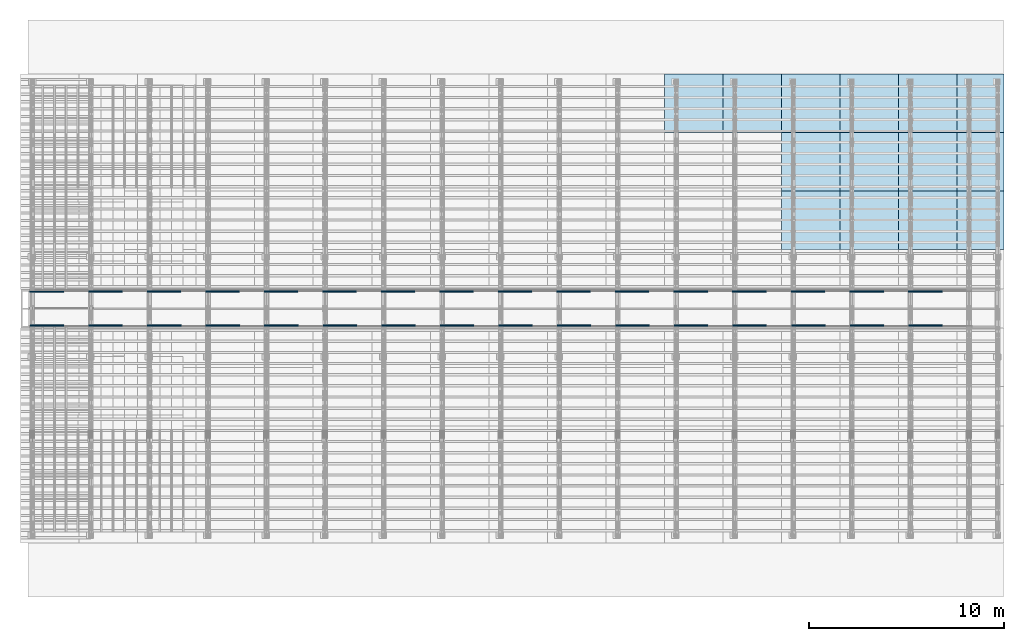
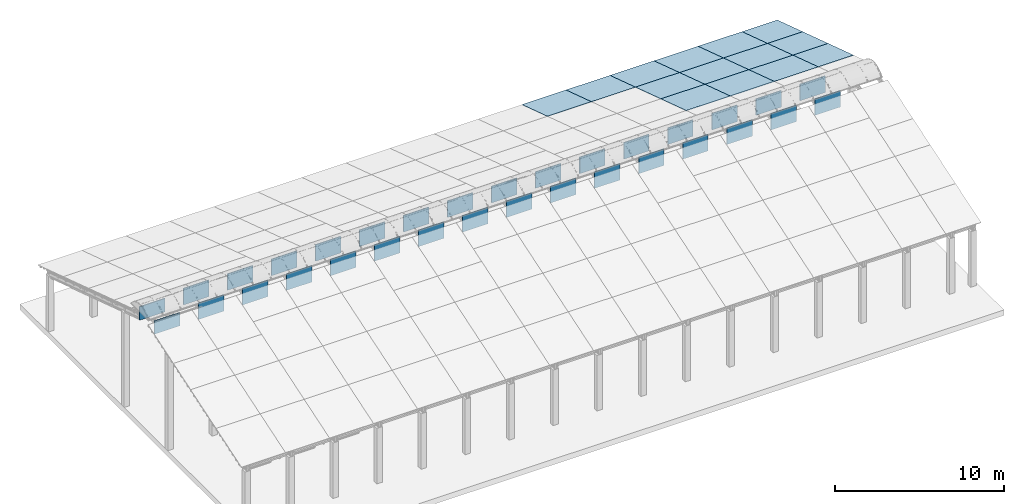
# One storey, part 10 of 385: 32 walls, 14 slabs, 14 elements without a shape of their own.
"""IFC2X3 building model written with IfcOpenShell, lengths in millimetres."""

from ifc_helpers import new_model, entity, si_unit, converted_unit, derived_unit, direction, frame, frame_2d, origin, place, context, subcontext, project, spatial, rectangle, extrude, material, layer, layer_set, layer_usage, type_object, element, aggregate, save


model = new_model("IFC2X3")

# Units and contexts
model_context = context("Model", 3, precision=0.01, world=origin(), true_north=direction((6.12303176911189e-17, 1.0)))
body_context = subcontext(model_context, "Body", "Model", "MODEL_VIEW")
ifc_project = project(units=[si_unit("LENGTHUNIT", "METRE", prefix="MILLI"), si_unit("AREAUNIT", "SQUARE_METRE"), si_unit("VOLUMEUNIT", "CUBIC_METRE"), converted_unit("PLANEANGLEUNIT", "DEGREE", entity("IfcRatioMeasure", 0.0174532925199433), si_unit("PLANEANGLEUNIT", "RADIAN"), dimensions=[0, 0, 0, 0, 0, 0, 0]), si_unit("MASSUNIT", "GRAM", prefix="KILO"), derived_unit("MASSDENSITYUNIT", [(si_unit("MASSUNIT", "GRAM", prefix="KILO"), 1), (si_unit("LENGTHUNIT", "METRE"), -3)]), si_unit("TIMEUNIT", "SECOND"), si_unit("FREQUENCYUNIT", "HERTZ"), si_unit("THERMODYNAMICTEMPERATUREUNIT", "DEGREE_CELSIUS"), derived_unit("THERMALTRANSMITTANCEUNIT", [(si_unit("MASSUNIT", "GRAM", prefix="KILO"), 1), (si_unit("THERMODYNAMICTEMPERATUREUNIT", "KELVIN"), -1), (si_unit("TIMEUNIT", "SECOND"), -3)]), derived_unit("VOLUMETRICFLOWRATEUNIT", [(si_unit("LENGTHUNIT", "METRE"), 3), (si_unit("TIMEUNIT", "SECOND"), -1)]), si_unit("ELECTRICCURRENTUNIT", "AMPERE"), si_unit("ELECTRICVOLTAGEUNIT", "VOLT"), si_unit("POWERUNIT", "WATT"), si_unit("FORCEUNIT", "NEWTON", prefix="KILO"), si_unit("ILLUMINANCEUNIT", "LUX"), si_unit("LUMINOUSFLUXUNIT", "LUMEN"), si_unit("LUMINOUSINTENSITYUNIT", "CANDELA"), derived_unit("USERDEFINED", [(si_unit("MASSUNIT", "GRAM", prefix="KILO"), -1), (si_unit("LENGTHUNIT", "METRE"), -2), (si_unit("TIMEUNIT", "SECOND"), 3), (si_unit("LUMINOUSFLUXUNIT", "LUMEN"), 1)]), derived_unit("LINEARVELOCITYUNIT", [(si_unit("LENGTHUNIT", "METRE"), 1), (si_unit("TIMEUNIT", "SECOND"), -1)]), si_unit("PRESSUREUNIT", "PASCAL"), derived_unit("USERDEFINED", [(si_unit("LENGTHUNIT", "METRE"), -2), (si_unit("MASSUNIT", "GRAM", prefix="KILO"), 1), (si_unit("TIMEUNIT", "SECOND"), -2)])], contexts=[model_context])

# Site, building, storey
site_placement = place(None, origin())
site = spatial("IfcSite", under=ifc_project, at=site_placement, CompositionType="ELEMENT")
building_placement = place(site_placement, origin())
building = spatial("IfcBuilding", under=site, at=building_placement, CompositionType="ELEMENT")
storey_placement = place(building_placement, origin())
storey = spatial("IfcBuildingStorey", under=building, at=storey_placement, Name="Default", CompositionType="ELEMENT", Elevation=0.0)

# Roof, slab
roof_1_placement = place(storey_placement, frame((32674.5090412161, 23742.4435684861, 594.897947736069)))
roof_1 = element("IfcRoof", 1, at=roof_1_placement, inside=storey, ShapeType="NOTDEFINED")
ifc_material_1 = material()
ifc_layer_1 = layer(ifc_material_1, 40.0)
ifc_layer_set_1 = layer_set([ifc_layer_1])
slab_1_placement = place(roof_1_placement, origin())
slab_1 = element("IfcSlab", 2, at=slab_1_placement, material=ifc_layer_set_1, PredefinedType="ROOF", context=body_context, shape_type="SweptSolid", body=[
    extrude(rectangle(XDim=3154.3866727148, YDim=2999.99999999999, at=frame_2d((0.0, 2.1600499167107e-12), x_axis=(0.0, 1.0))), frame((1500.0, 1500.0, 487.379544349359), z_axis=(0.0, 0.309016994374947, 0.951056516295154), x_axis=(1.0, 0.0, 0.0)), (0.0, -0.309016994374947, 0.951056516295154), 42.0584889695308),
])
aggregate(roof_1, [slab_1])

roof_2_placement = place(storey_placement, frame((35674.5090412161, 23742.4435684861, 594.897947736069)))
roof_2 = element("IfcRoof", 3, at=roof_2_placement, inside=storey, ShapeType="NOTDEFINED")
slab_2_placement = place(roof_2_placement, origin())
slab_2 = element("IfcSlab", 4, at=slab_2_placement, material=ifc_layer_set_1, PredefinedType="ROOF", context=body_context, shape_type="SweptSolid", body=[
    extrude(rectangle(XDim=3154.3866727148, YDim=2999.99999999999, at=frame_2d((0.0, 2.1600499167107e-12), x_axis=(0.0, 1.0))), frame((1500.0, 1500.0, 487.379544349359), z_axis=(0.0, 0.309016994374947, 0.951056516295154), x_axis=(1.0, 0.0, 0.0)), (0.0, -0.309016994374947, 0.951056516295154), 42.0584889695308),
])
aggregate(roof_2, [slab_2])

roof_3_placement = place(storey_placement, frame((38674.5090412161, 23742.4435684861, 594.897947736069)))
roof_3 = element("IfcRoof", 5, at=roof_3_placement, inside=storey, ShapeType="NOTDEFINED")
slab_3_placement = place(roof_3_placement, origin())
slab_3 = element("IfcSlab", 6, at=slab_3_placement, material=ifc_layer_set_1, PredefinedType="ROOF", context=body_context, shape_type="SweptSolid", body=[
    extrude(rectangle(XDim=3154.3866727148, YDim=2999.99999999999, at=frame_2d((-2.1600499167107e-12, 2.1600499167107e-12), x_axis=(0.0, 1.0))), frame((1500.0, 1500.0, 487.379544349359), z_axis=(0.0, 0.309016994374947, 0.951056516295154), x_axis=(1.0, 0.0, 0.0)), (0.0, -0.309016994374947, 0.951056516295154), 42.0584889695308),
])
aggregate(roof_3, [slab_3])

roof_4_placement = place(storey_placement, frame((38674.5090412161, 20742.4435684861, 1569.65703643478)))
roof_4 = element("IfcRoof", 7, at=roof_4_placement, inside=storey, ShapeType="NOTDEFINED")
slab_4_placement = place(roof_4_placement, origin())
slab_4 = element("IfcSlab", 8, at=slab_4_placement, material=ifc_layer_set_1, PredefinedType="ROOF", context=body_context, shape_type="SweptSolid", body=[
    extrude(rectangle(XDim=3154.3866727148, YDim=2999.99999999999, at=frame_2d((-2.1600499167107e-12, 1.13686837721616e-13), x_axis=(0.0, 1.0))), frame((1500.0, 1500.0, 487.379544349359), z_axis=(0.0, 0.309016994374947, 0.951056516295154), x_axis=(1.0, 0.0, 0.0)), (0.0, -0.309016994374947, 0.951056516295154), 42.0584889695308),
])
aggregate(roof_4, [slab_4])

roof_5_placement = place(storey_placement, frame((38674.5090412161, 17742.4435684861, 2544.4161251335)))
roof_5 = element("IfcRoof", 9, at=roof_5_placement, inside=storey, ShapeType="NOTDEFINED")
slab_5_placement = place(roof_5_placement, origin())
slab_5 = element("IfcSlab", 10, at=slab_5_placement, material=ifc_layer_set_1, PredefinedType="ROOF", context=body_context, shape_type="SweptSolid", body=[
    extrude(rectangle(XDim=3154.3866727148, YDim=2999.99999999999, at=frame_2d((-2.1600499167107e-12, 1.13686837721616e-12), x_axis=(0.0, 1.0))), frame((1500.0, 1500.0, 487.379544349359), z_axis=(0.0, 0.309016994374947, 0.951056516295154), x_axis=(1.0, 0.0, 0.0)), (0.0, -0.309016994374947, 0.951056516295154), 42.0584889695308),
])
aggregate(roof_5, [slab_5])

roof_6_placement = place(storey_placement, frame((41674.5090412161, 23742.443568486, 594.897947736069)))
roof_6 = element("IfcRoof", 11, at=roof_6_placement, inside=storey, ShapeType="NOTDEFINED")
slab_6_placement = place(roof_6_placement, origin())
slab_6 = element("IfcSlab", 12, at=slab_6_placement, material=ifc_layer_set_1, PredefinedType="ROOF", context=body_context, shape_type="SweptSolid", body=[
    extrude(rectangle(XDim=3154.3866727148, YDim=2999.99999999999, at=frame_2d((0.0, 2.1600499167107e-12), x_axis=(0.0, 1.0))), frame((1500.0, 1500.0, 487.379544349359), z_axis=(0.0, 0.309016994374947, 0.951056516295154), x_axis=(1.0, 0.0, 0.0)), (0.0, -0.309016994374947, 0.951056516295154), 42.0584889695308),
])
aggregate(roof_6, [slab_6])

roof_7_placement = place(storey_placement, frame((41674.5090412161, 20742.443568486, 1569.65703643478)))
roof_7 = element("IfcRoof", 13, at=roof_7_placement, inside=storey, ShapeType="NOTDEFINED")
slab_7_placement = place(roof_7_placement, origin())
slab_7 = element("IfcSlab", 14, at=slab_7_placement, material=ifc_layer_set_1, PredefinedType="ROOF", context=body_context, shape_type="SweptSolid", body=[
    extrude(rectangle(XDim=3154.3866727148, YDim=2999.99999999999, at=frame_2d((0.0, 1.13686837721616e-13), x_axis=(0.0, 1.0))), frame((1500.0, 1500.0, 487.379544349359), z_axis=(0.0, 0.309016994374947, 0.951056516295154), x_axis=(1.0, 0.0, 0.0)), (0.0, -0.309016994374947, 0.951056516295154), 42.0584889695308),
])
aggregate(roof_7, [slab_7])

roof_8_placement = place(storey_placement, frame((41674.5090412161, 17742.443568486, 2544.4161251335)))
roof_8 = element("IfcRoof", 15, at=roof_8_placement, inside=storey, ShapeType="NOTDEFINED")
slab_8_placement = place(roof_8_placement, origin())
slab_8 = element("IfcSlab", 16, at=slab_8_placement, material=ifc_layer_set_1, PredefinedType="ROOF", context=body_context, shape_type="SweptSolid", body=[
    extrude(rectangle(XDim=3154.3866727148, YDim=2999.99999999999, at=frame_2d((0.0, 1.13686837721616e-12), x_axis=(0.0, 1.0))), frame((1500.0, 1500.0, 487.379544349359), z_axis=(0.0, 0.309016994374947, 0.951056516295154), x_axis=(1.0, 0.0, 0.0)), (0.0, -0.309016994374947, 0.951056516295154), 42.0584889695308),
])
aggregate(roof_8, [slab_8])

roof_9_placement = place(storey_placement, frame((44674.5090412161, 23742.443568486, 594.897947736069)))
roof_9 = element("IfcRoof", 17, at=roof_9_placement, inside=storey, ShapeType="NOTDEFINED")
slab_9_placement = place(roof_9_placement, origin())
slab_9 = element("IfcSlab", 18, at=slab_9_placement, material=ifc_layer_set_1, PredefinedType="ROOF", context=body_context, shape_type="SweptSolid", body=[
    extrude(rectangle(XDim=3154.3866727148, YDim=2999.99999999999, at=frame_2d((0.0, 2.1600499167107e-12), x_axis=(0.0, 1.0))), frame((1500.0, 1500.0, 487.379544349359), z_axis=(0.0, 0.309016994374947, 0.951056516295154), x_axis=(1.0, 0.0, 0.0)), (0.0, -0.309016994374947, 0.951056516295154), 42.0584889695308),
])
aggregate(roof_9, [slab_9])

roof_10_placement = place(storey_placement, frame((44674.5090412161, 20742.443568486, 1569.65703643478)))
roof_10 = element("IfcRoof", 19, at=roof_10_placement, inside=storey, ShapeType="NOTDEFINED")
slab_10_placement = place(roof_10_placement, origin())
slab_10 = element("IfcSlab", 20, at=slab_10_placement, material=ifc_layer_set_1, PredefinedType="ROOF", context=body_context, shape_type="SweptSolid", body=[
    extrude(rectangle(XDim=3154.3866727148, YDim=2999.99999999999, at=frame_2d((0.0, 1.13686837721616e-13), x_axis=(0.0, 1.0))), frame((1500.0, 1500.0, 487.379544349359), z_axis=(0.0, 0.309016994374947, 0.951056516295154), x_axis=(1.0, 0.0, 0.0)), (0.0, -0.309016994374947, 0.951056516295154), 42.0584889695308),
])
aggregate(roof_10, [slab_10])

roof_11_placement = place(storey_placement, frame((44674.5090412161, 17742.443568486, 2544.4161251335)))
roof_11 = element("IfcRoof", 21, at=roof_11_placement, inside=storey, ShapeType="NOTDEFINED")
slab_11_placement = place(roof_11_placement, origin())
slab_11 = element("IfcSlab", 22, at=slab_11_placement, material=ifc_layer_set_1, PredefinedType="ROOF", context=body_context, shape_type="SweptSolid", body=[
    extrude(rectangle(XDim=3154.3866727148, YDim=2999.99999999999, at=frame_2d((0.0, 1.13686837721616e-12), x_axis=(0.0, 1.0))), frame((1500.0, 1500.0, 487.379544349359), z_axis=(0.0, 0.309016994374947, 0.951056516295154), x_axis=(1.0, 0.0, 0.0)), (0.0, -0.309016994374947, 0.951056516295154), 42.0584889695308),
])
aggregate(roof_11, [slab_11])

roof_12_placement = place(storey_placement, frame((47674.5090412161, 23742.443568486, 594.897947736069)))
roof_12 = element("IfcRoof", 23, at=roof_12_placement, inside=storey, ShapeType="NOTDEFINED")
slab_12_placement = place(roof_12_placement, origin())
slab_12 = element("IfcSlab", 24, at=slab_12_placement, material=ifc_layer_set_1, PredefinedType="ROOF", context=body_context, shape_type="SweptSolid", body=[
    extrude(rectangle(XDim=3154.3866727148, YDim=2400.0, at=frame_2d((4.32009983342141e-12, 2.1600499167107e-12), x_axis=(0.0, 1.0))), frame((1200.0, 1500.0, 487.379544349359), z_axis=(0.0, 0.309016994374947, 0.951056516295154), x_axis=(1.0, 0.0, 0.0)), (0.0, -0.309016994374947, 0.951056516295154), 42.0584889695308),
])
aggregate(roof_12, [slab_12])

roof_13_placement = place(storey_placement, frame((47674.5090412161, 20742.443568486, 1569.65703643478)))
roof_13 = element("IfcRoof", 25, at=roof_13_placement, inside=storey, ShapeType="NOTDEFINED")
slab_13_placement = place(roof_13_placement, origin())
slab_13 = element("IfcSlab", 26, at=slab_13_placement, material=ifc_layer_set_1, PredefinedType="ROOF", context=body_context, shape_type="SweptSolid", body=[
    extrude(rectangle(XDim=3154.3866727148, YDim=2400.0, at=frame_2d((4.32009983342141e-12, -1.13686837721616e-13), x_axis=(0.0, 1.0))), frame((1200.0, 1500.0, 487.37954434936), z_axis=(0.0, 0.309016994374947, 0.951056516295154), x_axis=(1.0, 0.0, 0.0)), (0.0, -0.309016994374947, 0.951056516295154), 42.0584889695308),
])
aggregate(roof_13, [slab_13])

roof_14_placement = place(storey_placement, frame((47674.5090412161, 17742.443568486, 2544.4161251335)))
roof_14 = element("IfcRoof", 27, at=roof_14_placement, inside=storey, ShapeType="NOTDEFINED")
slab_14_placement = place(roof_14_placement, origin())
slab_14 = element("IfcSlab", 28, at=slab_14_placement, material=ifc_layer_set_1, PredefinedType="ROOF", context=body_context, shape_type="SweptSolid", body=[
    extrude(rectangle(XDim=3154.3866727148, YDim=2400.0, at=frame_2d((4.32009983342141e-12, 1.02318153949454e-12), x_axis=(0.0, 1.0))), frame((1200.0, 1500.0, 487.379544349359), z_axis=(0.0, 0.309016994374947, 0.951056516295154), x_axis=(1.0, 0.0, 0.0)), (0.0, -0.309016994374947, 0.951056516295154), 42.0584889695308),
])
aggregate(roof_14, [slab_14])

# Walls
ifc_material_2 = material(Name="NLRS_n7_isolatie MegaPlus_Kingspan")
ifc_layer_2 = layer(ifc_material_2, 60.0)
ifc_layer_set_2 = layer_set([ifc_layer_2], Name="Basic Wall:Kingspan ALu")
ifc_layer_usage_1 = layer_usage(ifc_layer_set_2, "AXIS2", "NEGATIVE", 30.0)
wall_type = type_object("IfcWallType", Name="Basic Wall:Kingspan ALu", PredefinedType="STANDARD", material=ifc_layer_set_2)
wall_1_placement = place(building_placement, frame((157.932351536746, 15585.0, 3260.59379564744)))
element("IfcWallStandardCase", 29, at=wall_1_placement, inside=storey, type_object=wall_type, material=ifc_layer_usage_1, Name="Basic Wall:Kingspan ALu", ObjectType="Basic Wall:Kingspan ALu", context=body_context, shape_type="SweptSolid", body=[
    extrude(rectangle(XDim=1723.23881749108, YDim=59.9999999999994, at=frame_2d((861.61940874554, 0.0), x_axis=(-1.0, 0.0))), origin(), (0.0, 0.0, 1.0), 971.063028994697),
])
ifc_layer_usage_2 = layer_usage(ifc_layer_set_2, "AXIS2", "POSITIVE", -30.0)
wall_2_placement = place(storey_placement, frame((175.0, 13854.99980249, 3303.564525282)))
element("IfcWallStandardCase", 30, at=wall_2_placement, inside=storey, type_object=wall_type, material=ifc_layer_usage_2, Name="Basic Wall:Kingspan ALu", ObjectType="Basic Wall:Kingspan ALu", context=body_context, shape_type="SweptSolid", body=[
    extrude(rectangle(XDim=1723.23881749108, YDim=59.9999999999994, at=frame_2d((861.61940874554, -4.63629135083465e-13), x_axis=(-1.0, 0.0))), origin(), (0.0, 0.0, 1.0), 928.092299360147),
])
ifc_layer_usage_3 = layer_usage(ifc_layer_set_2, "AXIS2", "NEGATIVE", 30.0)
wall_3_placement = place(storey_placement, frame((3157.93235153675, 15595.4257355152, 3303.564525282)))
element("IfcWallStandardCase", 31, at=wall_3_placement, inside=storey, type_object=wall_type, material=ifc_layer_usage_3, Name="Basic Wall:Kingspan ALu", ObjectType="Basic Wall:Kingspan ALu", context=body_context, shape_type="SweptSolid", body=[
    extrude(rectangle(XDim=1723.23881749108, YDim=59.9999999999994, at=frame_2d((861.61940874554, 0.0), x_axis=(-1.0, 0.0))), origin(), (0.0, 0.0, 1.0), 1185.411009708),
])
ifc_layer_usage_4 = layer_usage(ifc_layer_set_2, "AXIS2", "POSITIVE", -30.0)
wall_4_placement = place(storey_placement, frame((3175.0, 13854.9998024899, 3303.564525282)))
element("IfcWallStandardCase", 32, at=wall_4_placement, inside=storey, type_object=wall_type, material=ifc_layer_usage_4, Name="Basic Wall:Kingspan ALu", ObjectType="Basic Wall:Kingspan ALu", context=body_context, shape_type="SweptSolid", body=[
    extrude(rectangle(XDim=1723.23881749108, YDim=59.9999999999994, at=frame_2d((861.61940874554, -4.63629135083465e-13), x_axis=(-1.0, 0.0))), origin(), (0.0, 0.0, 1.0), 1185.411009708),
])
ifc_layer_usage_5 = layer_usage(ifc_layer_set_2, "AXIS2", "NEGATIVE", 30.0)
wall_5_placement = place(storey_placement, frame((6157.93235153675, 15595.4257355152, 3303.564525282)))
element("IfcWallStandardCase", 33, at=wall_5_placement, inside=storey, type_object=wall_type, material=ifc_layer_usage_5, Name="Basic Wall:Kingspan ALu", ObjectType="Basic Wall:Kingspan ALu", context=body_context, shape_type="SweptSolid", body=[
    extrude(rectangle(XDim=1723.23881749108, YDim=59.9999999999994, at=frame_2d((861.61940874554, 0.0), x_axis=(-1.0, 0.0))), origin(), (0.0, 0.0, 1.0), 1185.411009708),
])
ifc_layer_usage_6 = layer_usage(ifc_layer_set_2, "AXIS2", "POSITIVE", -30.0)
wall_6_placement = place(storey_placement, frame((6175.0, 13854.9998024899, 3303.564525282)))
element("IfcWallStandardCase", 34, at=wall_6_placement, inside=storey, type_object=wall_type, material=ifc_layer_usage_6, Name="Basic Wall:Kingspan ALu", ObjectType="Basic Wall:Kingspan ALu", context=body_context, shape_type="SweptSolid", body=[
    extrude(rectangle(XDim=1723.23881749108, YDim=59.9999999999994, at=frame_2d((861.61940874554, -4.63629135083465e-13), x_axis=(-1.0, 0.0))), origin(), (0.0, 0.0, 1.0), 1185.411009708),
])
ifc_layer_usage_7 = layer_usage(ifc_layer_set_2, "AXIS2", "NEGATIVE", 30.0)
wall_7_placement = place(storey_placement, frame((9157.93235153675, 15595.4257355152, 3303.564525282)))
element("IfcWallStandardCase", 35, at=wall_7_placement, inside=storey, type_object=wall_type, material=ifc_layer_usage_7, Name="Basic Wall:Kingspan ALu", ObjectType="Basic Wall:Kingspan ALu", context=body_context, shape_type="SweptSolid", body=[
    extrude(rectangle(XDim=1723.23881749108, YDim=59.9999999999994, at=frame_2d((861.61940874554, 0.0), x_axis=(-1.0, 0.0))), origin(), (0.0, 0.0, 1.0), 1185.411009708),
])
ifc_layer_usage_8 = layer_usage(ifc_layer_set_2, "AXIS2", "POSITIVE", -30.0)
wall_8_placement = place(storey_placement, frame((9175.0, 13854.9998024899, 3303.564525282)))
element("IfcWallStandardCase", 36, at=wall_8_placement, inside=storey, type_object=wall_type, material=ifc_layer_usage_8, Name="Basic Wall:Kingspan ALu", ObjectType="Basic Wall:Kingspan ALu", context=body_context, shape_type="SweptSolid", body=[
    extrude(rectangle(XDim=1723.23881749108, YDim=59.9999999999994, at=frame_2d((861.61940874554, -4.63629135083465e-13), x_axis=(-1.0, 0.0))), origin(), (0.0, 0.0, 1.0), 1185.411009708),
])
ifc_layer_usage_9 = layer_usage(ifc_layer_set_2, "AXIS2", "NEGATIVE", 30.0)
wall_9_placement = place(storey_placement, frame((12157.9323515367, 15595.4257355152, 3303.564525282)))
element("IfcWallStandardCase", 37, at=wall_9_placement, inside=storey, type_object=wall_type, material=ifc_layer_usage_9, Name="Basic Wall:Kingspan ALu", ObjectType="Basic Wall:Kingspan ALu", context=body_context, shape_type="SweptSolid", body=[
    extrude(rectangle(XDim=1723.23881749108, YDim=59.9999999999994, at=frame_2d((861.61940874554, 0.0), x_axis=(-1.0, 0.0))), origin(), (0.0, 0.0, 1.0), 1185.411009708),
])
ifc_layer_usage_10 = layer_usage(ifc_layer_set_2, "AXIS2", "POSITIVE", -30.0)
wall_10_placement = place(storey_placement, frame((12175.0, 13854.9998024899, 3303.564525282)))
element("IfcWallStandardCase", 38, at=wall_10_placement, inside=storey, type_object=wall_type, material=ifc_layer_usage_10, Name="Basic Wall:Kingspan ALu", ObjectType="Basic Wall:Kingspan ALu", context=body_context, shape_type="SweptSolid", body=[
    extrude(rectangle(XDim=1723.23881749108, YDim=59.9999999999994, at=frame_2d((861.61940874554, -4.63629135083465e-13), x_axis=(-1.0, 0.0))), origin(), (0.0, 0.0, 1.0), 1185.411009708),
])
ifc_layer_usage_11 = layer_usage(ifc_layer_set_2, "AXIS2", "NEGATIVE", 30.0)
wall_11_placement = place(storey_placement, frame((15157.9323515367, 15595.4257355152, 3303.564525282)))
element("IfcWallStandardCase", 39, at=wall_11_placement, inside=storey, type_object=wall_type, material=ifc_layer_usage_11, Name="Basic Wall:Kingspan ALu", ObjectType="Basic Wall:Kingspan ALu", context=body_context, shape_type="SweptSolid", body=[
    extrude(rectangle(XDim=1723.23881749108, YDim=59.9999999999994, at=frame_2d((861.61940874554, 0.0), x_axis=(-1.0, 0.0))), origin(), (0.0, 0.0, 1.0), 1185.411009708),
])
ifc_layer_usage_12 = layer_usage(ifc_layer_set_2, "AXIS2", "POSITIVE", -30.0)
wall_12_placement = place(storey_placement, frame((15175.0, 13854.9998024899, 3303.564525282)))
element("IfcWallStandardCase", 40, at=wall_12_placement, inside=storey, type_object=wall_type, material=ifc_layer_usage_12, Name="Basic Wall:Kingspan ALu", ObjectType="Basic Wall:Kingspan ALu", context=body_context, shape_type="SweptSolid", body=[
    extrude(rectangle(XDim=1723.23881749108, YDim=59.9999999999994, at=frame_2d((861.61940874554, -4.63629135083465e-13), x_axis=(-1.0, 0.0))), origin(), (0.0, 0.0, 1.0), 1185.411009708),
])
ifc_layer_usage_13 = layer_usage(ifc_layer_set_2, "AXIS2", "NEGATIVE", 30.0)
wall_13_placement = place(storey_placement, frame((18157.9323515367, 15595.4257355152, 3303.564525282)))
element("IfcWallStandardCase", 41, at=wall_13_placement, inside=storey, type_object=wall_type, material=ifc_layer_usage_13, Name="Basic Wall:Kingspan ALu", ObjectType="Basic Wall:Kingspan ALu", context=body_context, shape_type="SweptSolid", body=[
    extrude(rectangle(XDim=1723.23881749108, YDim=59.9999999999994, at=frame_2d((861.61940874554, 0.0), x_axis=(-1.0, 0.0))), origin(), (0.0, 0.0, 1.0), 1185.411009708),
])
ifc_layer_usage_14 = layer_usage(ifc_layer_set_2, "AXIS2", "POSITIVE", -30.0)
wall_14_placement = place(storey_placement, frame((18175.0, 13854.9998024899, 3303.564525282)))
element("IfcWallStandardCase", 42, at=wall_14_placement, inside=storey, type_object=wall_type, material=ifc_layer_usage_14, Name="Basic Wall:Kingspan ALu", ObjectType="Basic Wall:Kingspan ALu", context=body_context, shape_type="SweptSolid", body=[
    extrude(rectangle(XDim=1723.23881749108, YDim=59.9999999999994, at=frame_2d((861.61940874554, -4.63629135083465e-13), x_axis=(-1.0, 0.0))), origin(), (0.0, 0.0, 1.0), 1185.411009708),
])
ifc_layer_usage_15 = layer_usage(ifc_layer_set_2, "AXIS2", "NEGATIVE", 30.0)
wall_15_placement = place(storey_placement, frame((21157.9323515368, 15595.4257355152, 3303.564525282)))
element("IfcWallStandardCase", 43, at=wall_15_placement, inside=storey, type_object=wall_type, material=ifc_layer_usage_15, Name="Basic Wall:Kingspan ALu", ObjectType="Basic Wall:Kingspan ALu", context=body_context, shape_type="SweptSolid", body=[
    extrude(rectangle(XDim=1723.23881749108, YDim=59.9999999999994, at=frame_2d((861.61940874554, 0.0), x_axis=(-1.0, 0.0))), origin(), (0.0, 0.0, 1.0), 1185.411009708),
])
ifc_layer_usage_16 = layer_usage(ifc_layer_set_2, "AXIS2", "POSITIVE", -30.0)
wall_16_placement = place(storey_placement, frame((21175.0, 13854.9998024899, 3303.564525282)))
element("IfcWallStandardCase", 44, at=wall_16_placement, inside=storey, type_object=wall_type, material=ifc_layer_usage_16, Name="Basic Wall:Kingspan ALu", ObjectType="Basic Wall:Kingspan ALu", context=body_context, shape_type="SweptSolid", body=[
    extrude(rectangle(XDim=1723.23881749108, YDim=59.9999999999994, at=frame_2d((861.61940874554, -4.63629135083465e-13), x_axis=(-1.0, 0.0))), origin(), (0.0, 0.0, 1.0), 1185.411009708),
])
ifc_layer_usage_17 = layer_usage(ifc_layer_set_2, "AXIS2", "NEGATIVE", 30.0)
wall_17_placement = place(storey_placement, frame((24157.9323515367, 15595.4257355152, 3303.564525282)))
element("IfcWallStandardCase", 45, at=wall_17_placement, inside=storey, type_object=wall_type, material=ifc_layer_usage_17, Name="Basic Wall:Kingspan ALu", ObjectType="Basic Wall:Kingspan ALu", context=body_context, shape_type="SweptSolid", body=[
    extrude(rectangle(XDim=1723.23881749108, YDim=59.9999999999994, at=frame_2d((861.61940874554, 0.0), x_axis=(-1.0, 0.0))), origin(), (0.0, 0.0, 1.0), 1185.411009708),
])
ifc_layer_usage_18 = layer_usage(ifc_layer_set_2, "AXIS2", "POSITIVE", -30.0)
wall_18_placement = place(storey_placement, frame((24175.0, 13854.9998024899, 3303.564525282)))
element("IfcWallStandardCase", 46, at=wall_18_placement, inside=storey, type_object=wall_type, material=ifc_layer_usage_18, Name="Basic Wall:Kingspan ALu", ObjectType="Basic Wall:Kingspan ALu", context=body_context, shape_type="SweptSolid", body=[
    extrude(rectangle(XDim=1723.23881749108, YDim=59.9999999999994, at=frame_2d((861.61940874554, -4.63629135083465e-13), x_axis=(-1.0, 0.0))), origin(), (0.0, 0.0, 1.0), 1185.411009708),
])
ifc_layer_usage_19 = layer_usage(ifc_layer_set_2, "AXIS2", "NEGATIVE", 30.0)
wall_19_placement = place(storey_placement, frame((27157.9323515368, 15595.4257355152, 3303.564525282)))
element("IfcWallStandardCase", 47, at=wall_19_placement, inside=storey, type_object=wall_type, material=ifc_layer_usage_19, Name="Basic Wall:Kingspan ALu", ObjectType="Basic Wall:Kingspan ALu", context=body_context, shape_type="SweptSolid", body=[
    extrude(rectangle(XDim=1723.23881749108, YDim=59.9999999999994, at=frame_2d((861.61940874554, 0.0), x_axis=(-1.0, 0.0))), origin(), (0.0, 0.0, 1.0), 1185.411009708),
])
ifc_layer_usage_20 = layer_usage(ifc_layer_set_2, "AXIS2", "POSITIVE", -30.0)
wall_20_placement = place(storey_placement, frame((27175.0, 13854.9998024899, 3303.564525282)))
element("IfcWallStandardCase", 48, at=wall_20_placement, inside=storey, type_object=wall_type, material=ifc_layer_usage_20, Name="Basic Wall:Kingspan ALu", ObjectType="Basic Wall:Kingspan ALu", context=body_context, shape_type="SweptSolid", body=[
    extrude(rectangle(XDim=1723.23881749108, YDim=59.9999999999994, at=frame_2d((861.61940874554, -4.63629135083465e-13), x_axis=(-1.0, 0.0))), origin(), (0.0, 0.0, 1.0), 1185.411009708),
])
ifc_layer_usage_21 = layer_usage(ifc_layer_set_2, "AXIS2", "NEGATIVE", 30.0)
wall_21_placement = place(storey_placement, frame((30157.9323515367, 15595.4257355152, 3303.564525282)))
element("IfcWallStandardCase", 49, at=wall_21_placement, inside=storey, type_object=wall_type, material=ifc_layer_usage_21, Name="Basic Wall:Kingspan ALu", ObjectType="Basic Wall:Kingspan ALu", context=body_context, shape_type="SweptSolid", body=[
    extrude(rectangle(XDim=1723.23881749108, YDim=59.9999999999994, at=frame_2d((861.61940874554, 0.0), x_axis=(-1.0, 0.0))), origin(), (0.0, 0.0, 1.0), 1185.411009708),
])
ifc_layer_usage_22 = layer_usage(ifc_layer_set_2, "AXIS2", "POSITIVE", -30.0)
wall_22_placement = place(storey_placement, frame((30175.0, 13854.9998024899, 3303.564525282)))
element("IfcWallStandardCase", 50, at=wall_22_placement, inside=storey, type_object=wall_type, material=ifc_layer_usage_22, Name="Basic Wall:Kingspan ALu", ObjectType="Basic Wall:Kingspan ALu", context=body_context, shape_type="SweptSolid", body=[
    extrude(rectangle(XDim=1723.23881749108, YDim=59.9999999999994, at=frame_2d((861.61940874554, -4.63629135083465e-13), x_axis=(-1.0, 0.0))), origin(), (0.0, 0.0, 1.0), 1185.411009708),
])
ifc_layer_usage_23 = layer_usage(ifc_layer_set_2, "AXIS2", "NEGATIVE", 30.0)
wall_23_placement = place(storey_placement, frame((33157.9323515367, 15595.4257355152, 3303.564525282)))
element("IfcWallStandardCase", 51, at=wall_23_placement, inside=storey, type_object=wall_type, material=ifc_layer_usage_23, Name="Basic Wall:Kingspan ALu", ObjectType="Basic Wall:Kingspan ALu", context=body_context, shape_type="SweptSolid", body=[
    extrude(rectangle(XDim=1723.23881749108, YDim=59.9999999999994, at=frame_2d((861.61940874554, 0.0), x_axis=(-1.0, 0.0))), origin(), (0.0, 0.0, 1.0), 1185.411009708),
])
ifc_layer_usage_24 = layer_usage(ifc_layer_set_2, "AXIS2", "POSITIVE", -30.0)
wall_24_placement = place(storey_placement, frame((33175.0, 13854.9998024899, 3303.564525282)))
element("IfcWallStandardCase", 52, at=wall_24_placement, inside=storey, type_object=wall_type, material=ifc_layer_usage_24, Name="Basic Wall:Kingspan ALu", ObjectType="Basic Wall:Kingspan ALu", context=body_context, shape_type="SweptSolid", body=[
    extrude(rectangle(XDim=1723.23881749108, YDim=59.9999999999994, at=frame_2d((861.61940874554, -4.63629135083465e-13), x_axis=(-1.0, 0.0))), origin(), (0.0, 0.0, 1.0), 1185.411009708),
])
ifc_layer_usage_25 = layer_usage(ifc_layer_set_2, "AXIS2", "NEGATIVE", 30.0)
wall_25_placement = place(storey_placement, frame((36157.9323515368, 15595.4257355152, 3303.564525282)))
element("IfcWallStandardCase", 53, at=wall_25_placement, inside=storey, type_object=wall_type, material=ifc_layer_usage_25, Name="Basic Wall:Kingspan ALu", ObjectType="Basic Wall:Kingspan ALu", context=body_context, shape_type="SweptSolid", body=[
    extrude(rectangle(XDim=1723.23881749108, YDim=59.9999999999994, at=frame_2d((861.61940874554, 0.0), x_axis=(-1.0, 0.0))), origin(), (0.0, 0.0, 1.0), 1185.411009708),
])
ifc_layer_usage_26 = layer_usage(ifc_layer_set_2, "AXIS2", "POSITIVE", -30.0)
wall_26_placement = place(storey_placement, frame((36175.0, 13854.9998024899, 3303.564525282)))
element("IfcWallStandardCase", 54, at=wall_26_placement, inside=storey, type_object=wall_type, material=ifc_layer_usage_26, Name="Basic Wall:Kingspan ALu", ObjectType="Basic Wall:Kingspan ALu", context=body_context, shape_type="SweptSolid", body=[
    extrude(rectangle(XDim=1723.23881749108, YDim=59.9999999999994, at=frame_2d((861.61940874554, -4.63629135083465e-13), x_axis=(-1.0, 0.0))), origin(), (0.0, 0.0, 1.0), 1185.411009708),
])
ifc_layer_usage_27 = layer_usage(ifc_layer_set_2, "AXIS2", "NEGATIVE", 30.0)
wall_27_placement = place(storey_placement, frame((39177.9323515367, 15595.4257355151, 3303.564525282)))
element("IfcWallStandardCase", 55, at=wall_27_placement, inside=storey, type_object=wall_type, material=ifc_layer_usage_27, Name="Basic Wall:Kingspan ALu", ObjectType="Basic Wall:Kingspan ALu", context=body_context, shape_type="SweptSolid", body=[
    extrude(rectangle(XDim=1723.23881749108, YDim=59.9999999999994, at=frame_2d((861.61940874554, 0.0), x_axis=(-1.0, 0.0))), origin(), (0.0, 0.0, 1.0), 1185.411009708),
])
ifc_layer_usage_28 = layer_usage(ifc_layer_set_2, "AXIS2", "POSITIVE", -30.0)
wall_28_placement = place(storey_placement, frame((39195.0, 13854.9998024898, 3303.564525282)))
element("IfcWallStandardCase", 56, at=wall_28_placement, inside=storey, type_object=wall_type, material=ifc_layer_usage_28, Name="Basic Wall:Kingspan ALu", ObjectType="Basic Wall:Kingspan ALu", context=body_context, shape_type="SweptSolid", body=[
    extrude(rectangle(XDim=1723.23881749108, YDim=59.9999999999994, at=frame_2d((861.61940874554, -4.63629135083465e-13), x_axis=(-1.0, 0.0))), origin(), (0.0, 0.0, 1.0), 1185.411009708),
])
ifc_layer_usage_29 = layer_usage(ifc_layer_set_2, "AXIS2", "NEGATIVE", 30.0)
wall_29_placement = place(storey_placement, frame((42177.9323515367, 15595.4257355151, 3303.564525282)))
element("IfcWallStandardCase", 57, at=wall_29_placement, inside=storey, type_object=wall_type, material=ifc_layer_usage_29, Name="Basic Wall:Kingspan ALu", ObjectType="Basic Wall:Kingspan ALu", context=body_context, shape_type="SweptSolid", body=[
    extrude(rectangle(XDim=1723.23881749108, YDim=59.9999999999994, at=frame_2d((861.61940874554, 0.0), x_axis=(-1.0, 0.0))), origin(), (0.0, 0.0, 1.0), 1185.411009708),
])
ifc_layer_usage_30 = layer_usage(ifc_layer_set_2, "AXIS2", "POSITIVE", -30.0)
wall_30_placement = place(storey_placement, frame((42195.0, 13854.9998024898, 3303.564525282)))
element("IfcWallStandardCase", 58, at=wall_30_placement, inside=storey, type_object=wall_type, material=ifc_layer_usage_30, Name="Basic Wall:Kingspan ALu", ObjectType="Basic Wall:Kingspan ALu", context=body_context, shape_type="SweptSolid", body=[
    extrude(rectangle(XDim=1723.23881749108, YDim=59.9999999999994, at=frame_2d((861.61940874554, -4.63629135083465e-13), x_axis=(-1.0, 0.0))), origin(), (0.0, 0.0, 1.0), 1185.411009708),
])
ifc_layer_usage_31 = layer_usage(ifc_layer_set_2, "AXIS2", "NEGATIVE", 30.0)
wall_31_placement = place(storey_placement, frame((45177.9323515367, 15595.4257355151, 3303.564525282)))
element("IfcWallStandardCase", 59, at=wall_31_placement, inside=storey, type_object=wall_type, material=ifc_layer_usage_31, Name="Basic Wall:Kingspan ALu", ObjectType="Basic Wall:Kingspan ALu", context=body_context, shape_type="SweptSolid", body=[
    extrude(rectangle(XDim=1723.23881749108, YDim=59.9999999999994, at=frame_2d((861.61940874554, 0.0), x_axis=(-1.0, 0.0))), origin(), (0.0, 0.0, 1.0), 1185.411009708),
])
ifc_layer_usage_32 = layer_usage(ifc_layer_set_2, "AXIS2", "POSITIVE", -30.0)
wall_32_placement = place(storey_placement, frame((45195.0, 13854.9998024898, 3303.564525282)))
element("IfcWallStandardCase", 60, at=wall_32_placement, inside=storey, type_object=wall_type, material=ifc_layer_usage_32, Name="Basic Wall:Kingspan ALu", ObjectType="Basic Wall:Kingspan ALu", context=body_context, shape_type="SweptSolid", body=[
    extrude(rectangle(XDim=1723.23881749108, YDim=59.9999999999994, at=frame_2d((861.61940874554, -4.63629135083465e-13), x_axis=(-1.0, 0.0))), origin(), (0.0, 0.0, 1.0), 1185.411009708),
])

save(model, "model.ifc")
